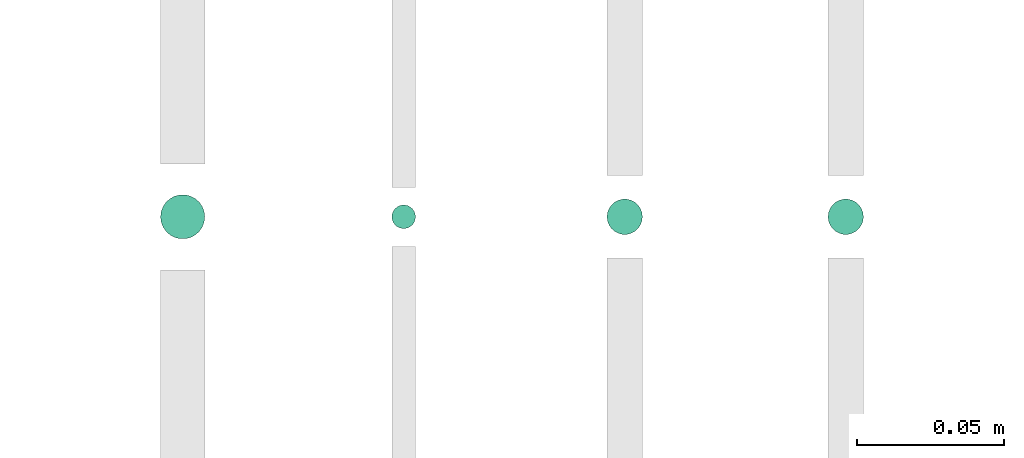
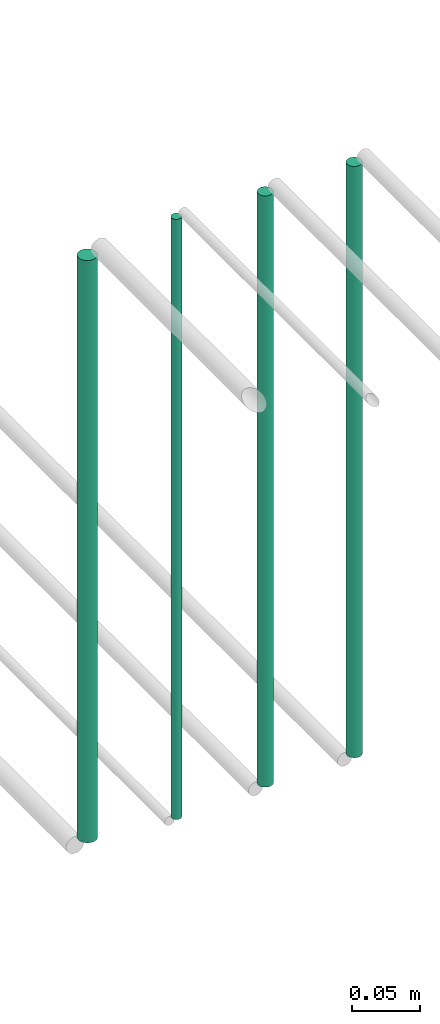
# One storey, part 38 of 65: 4 flow segments.
"""IFC2X3 building model written with IfcOpenShell, lengths in millimetres."""

from ifc_helpers import new_model, entity, si_unit, converted_unit, derived_unit, direction, frame, frame_2d, origin, origin_2d_with_axis, place, context, subcontext, project, spatial, circle, extrude, type_object, element, save


model = new_model("IFC2X3")

# Units and contexts
model_context = context("Model", 3, precision=0.01, world=origin(), true_north=direction((6.12303176911189e-17, 1.0)))
body_context = subcontext(model_context, "Body", "Model", "MODEL_VIEW")
ifc_project = project(units=[si_unit("LENGTHUNIT", "METRE", prefix="MILLI"), si_unit("AREAUNIT", "SQUARE_METRE"), si_unit("VOLUMEUNIT", "CUBIC_METRE"), converted_unit("PLANEANGLEUNIT", "DEGREE", entity("IfcRatioMeasure", 0.0174532925199433), si_unit("PLANEANGLEUNIT", "RADIAN"), dimensions=[0, 0, 0, 0, 0, 0, 0]), si_unit("MASSUNIT", "GRAM", prefix="KILO"), derived_unit("MASSDENSITYUNIT", [(si_unit("MASSUNIT", "GRAM", prefix="KILO"), 1), (si_unit("LENGTHUNIT", "METRE"), -3)]), derived_unit("MOMENTOFINERTIAUNIT", [(si_unit("LENGTHUNIT", "METRE"), 4)]), si_unit("TIMEUNIT", "SECOND"), si_unit("FREQUENCYUNIT", "HERTZ"), si_unit("THERMODYNAMICTEMPERATUREUNIT", "DEGREE_CELSIUS"), derived_unit("THERMALTRANSMITTANCEUNIT", [(si_unit("MASSUNIT", "GRAM", prefix="KILO"), 1), (si_unit("THERMODYNAMICTEMPERATUREUNIT", "KELVIN"), -1), (si_unit("TIMEUNIT", "SECOND"), -3)]), derived_unit("VOLUMETRICFLOWRATEUNIT", [(si_unit("LENGTHUNIT", "METRE"), 3), (si_unit("TIMEUNIT", "SECOND"), -1)]), derived_unit("MASSFLOWRATEUNIT", [(si_unit("MASSUNIT", "GRAM", prefix="KILO"), 1), (si_unit("TIMEUNIT", "SECOND"), -1)]), derived_unit("ROTATIONALFREQUENCYUNIT", [(si_unit("TIMEUNIT", "SECOND"), -1)]), si_unit("ELECTRICCURRENTUNIT", "AMPERE"), si_unit("ELECTRICVOLTAGEUNIT", "VOLT"), si_unit("POWERUNIT", "WATT"), si_unit("FORCEUNIT", "NEWTON", prefix="KILO"), si_unit("ILLUMINANCEUNIT", "LUX"), si_unit("LUMINOUSFLUXUNIT", "LUMEN"), si_unit("LUMINOUSINTENSITYUNIT", "CANDELA"), derived_unit("USERDEFINED", [(si_unit("MASSUNIT", "GRAM", prefix="KILO"), -1), (si_unit("LENGTHUNIT", "METRE"), -2), (si_unit("TIMEUNIT", "SECOND"), 3), (si_unit("LUMINOUSFLUXUNIT", "LUMEN"), 1)]), derived_unit("LINEARVELOCITYUNIT", [(si_unit("LENGTHUNIT", "METRE"), 1), (si_unit("TIMEUNIT", "SECOND"), -1)]), si_unit("PRESSUREUNIT", "PASCAL"), derived_unit("USERDEFINED", [(si_unit("LENGTHUNIT", "METRE"), -2), (si_unit("MASSUNIT", "GRAM", prefix="KILO"), 1), (si_unit("TIMEUNIT", "SECOND"), -2)]), derived_unit("LINEARFORCEUNIT", [(si_unit("MASSUNIT", "GRAM", prefix="KILO"), 1), (si_unit("LENGTHUNIT", "METRE"), 1), (si_unit("TIMEUNIT", "SECOND"), -2), (si_unit("LENGTHUNIT", "METRE"), -1)]), derived_unit("PLANARFORCEUNIT", [(si_unit("MASSUNIT", "GRAM", prefix="KILO"), 1), (si_unit("LENGTHUNIT", "METRE"), 1), (si_unit("TIMEUNIT", "SECOND"), -2), (si_unit("LENGTHUNIT", "METRE"), -2)])], contexts=[model_context])

# Site, building, storey
site_placement = place(None, frame((0.0, -0.00077364408347762, 0.0)))
site = spatial("IfcSite", under=ifc_project, at=site_placement, CompositionType="ELEMENT")
building_placement = place(site_placement, origin())
building = spatial("IfcBuilding", under=site, at=building_placement, CompositionType="ELEMENT")
storey_placement = place(building_placement, frame((0.0, 0.0, 19800.0)))
storey = spatial("IfcBuildingStorey", under=building, at=storey_placement, CompositionType="ELEMENT", Elevation=19800.0)

# Flow segments
pipe_segment_type = type_object("IfcPipeSegmentType", PredefinedType="NOTDEFINED")
flow_segment_1_placement = place(storey_placement, frame((50856.8052438068, 4690.9047277641, 2643.0)))
element("IfcFlowSegment", 1, at=flow_segment_1_placement, inside=storey, type_object=pipe_segment_type, context=body_context, shape_type="SweptSolid", body=[
    extrude(circle(Radius=7.5, at=origin_2d_with_axis()), frame((9.09527223591419, 9.09527223591582, 0.0), z_axis=(0.0, 0.0, 1.0), x_axis=(-1.0, 0.0, 0.0)), (0.0, 0.0, 1.0), 518.999999999817),
])
flow_segment_2_placement = place(storey_placement, frame((50935.3052438068, 4694.4047277641, 2635.0)))
element("IfcFlowSegment", 2, at=flow_segment_2_placement, inside=storey, type_object=pipe_segment_type, context=body_context, shape_type="SweptSolid", body=[
    extrude(circle(Radius=4.0, at=origin_2d_with_axis()), frame((5.59527223591499, 5.59527223591607, 0.0), z_axis=(0.0, 0.0, 1.0), x_axis=(-1.0, 0.0, 0.0)), (0.0, 0.0, 1.0), 535.000000000099),
])
flow_segment_3_placement = place(storey_placement, frame((51008.3052438068, 4692.40472776412, 2639.0)))
element("IfcFlowSegment", 3, at=flow_segment_3_placement, inside=storey, type_object=pipe_segment_type, context=body_context, shape_type="SweptSolid", body=[
    extrude(circle(Radius=6.0, at=frame_2d((0.0, -5.41433564649196e-13), x_axis=(1.0, 0.0))), frame((7.59527223591454, 7.5952722359167, 0.0)), (0.0, 0.0, 1.0), 527.000000000162),
])
flow_segment_4_placement = place(storey_placement, frame((51083.3052438068, 4692.4047277641, 2639.0)))
element("IfcFlowSegment", 4, at=flow_segment_4_placement, inside=storey, type_object=pipe_segment_type, context=body_context, shape_type="SweptSolid", body=[
    extrude(circle(Radius=6.0, at=frame_2d((0.0, 5.41433564649196e-13), x_axis=(1.0, 0.0))), frame((7.59527223591454, 7.5952722359167, 0.0), z_axis=(0.0, 0.0, 1.0), x_axis=(-1.0, 0.0, 0.0)), (0.0, 0.0, 1.0), 527.000000000058),
])

save(model, "model.ifc")
